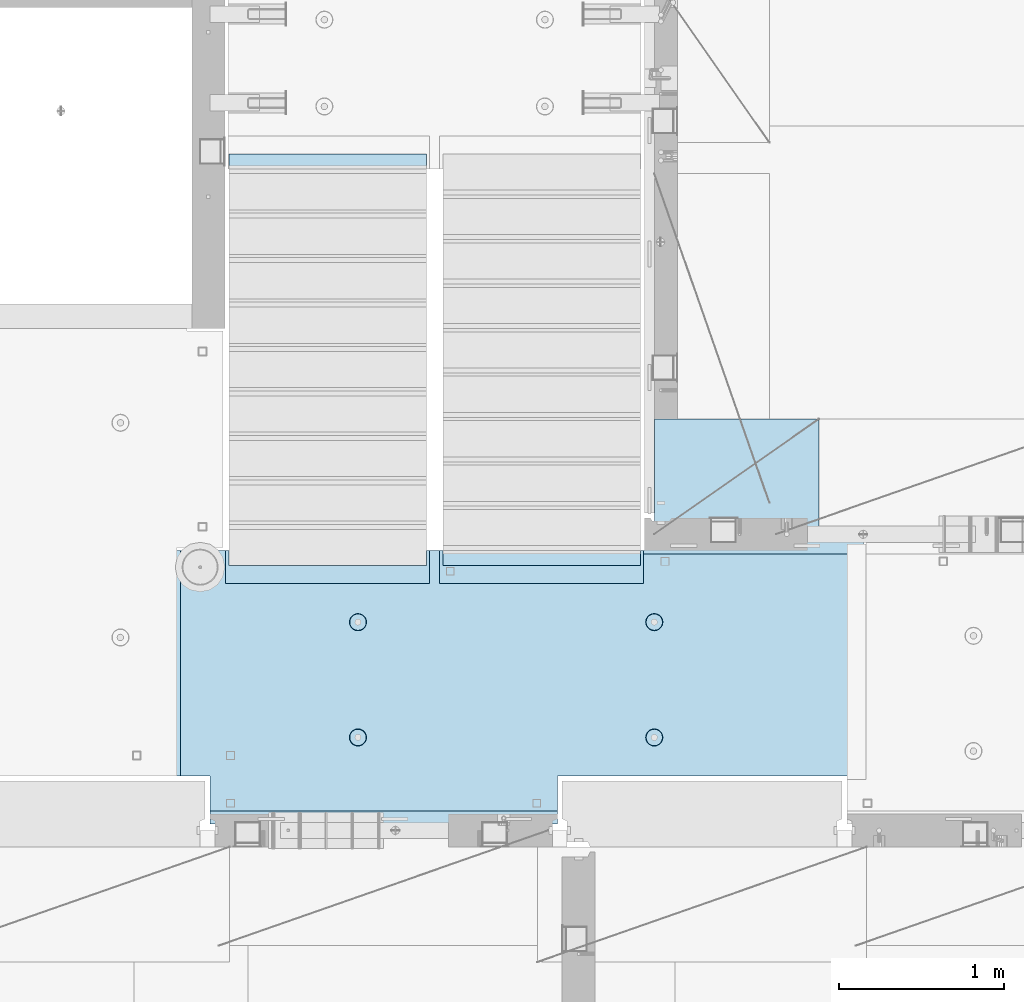
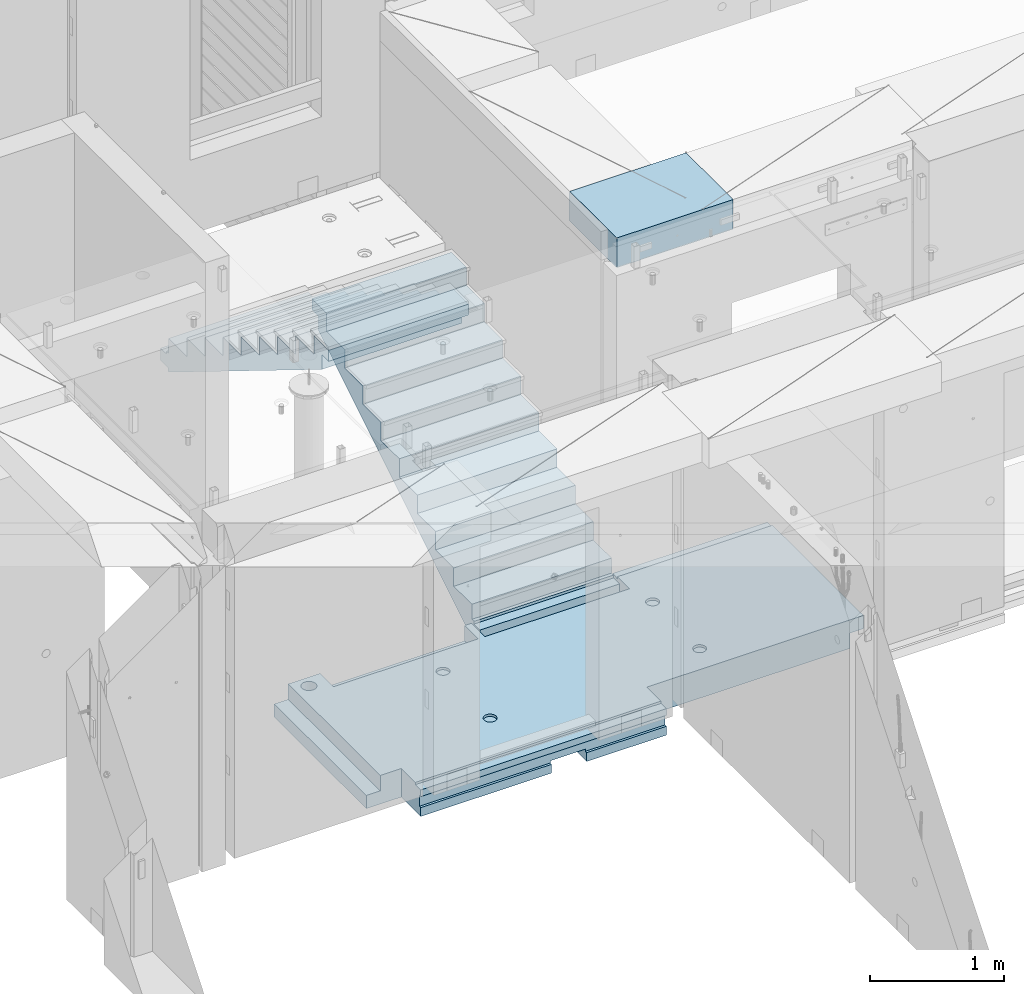
# One storey, part 207 of 352: 3 plates, 1 slab, 4 elements without a shape of their own.
"""IFC2X3 building model written with IfcOpenShell, lengths in millimetres."""

import ifcopenshell
import ifcopenshell.guid

model = None  # the IFC model being written
_history = None  # IfcOwnerHistory: only IFC2X3 demands one
_inside = {}  # id of a spatial element -> (the spatial element, [elements in it])
_under = {}  # id of a project, library or spatial element -> (it, [spatial elements below it])
_declared = {}  # id of a project -> (the project, [libraries it declares])
_typed = {}  # id of a type object -> (the type object, [elements of that type])
_made_of = {}  # id of a material, layer set ... -> (it, [elements and type objects made of it])


def new_model(schema):
    """Start an empty IFC model of exactly this schema.

    Asked for "IFC4X3", IfcOpenShell would pick the latest addendum, in which some entities
    have other attributes; the version numbers below select the first issue.
    IFC2X3 requires an IfcOwnerHistory on every rooted entity: one is made here for all.
    """
    global model, _history
    if schema == "IFC4X3":
        model = ifcopenshell.file(schema_version=(4, 3, 0, 0))
    else:
        model = ifcopenshell.file(schema=schema)
    _inside.clear()
    _under.clear()
    _declared.clear()
    _typed.clear()
    _made_of.clear()
    _history = None
    if model.schema == "IFC2X3":
        org = make("IfcOrganization", Name="unknown")
        user = make(
            "IfcPersonAndOrganization",
            ThePerson=make("IfcPerson", FamilyName="unknown"),
            TheOrganization=org,
        )
        app = make(
            "IfcApplication",
            ApplicationDeveloper=org,
            Version="unknown",
            ApplicationFullName="unknown",
            ApplicationIdentifier="unknown",
        )
        _history = make(
            "IfcOwnerHistory",
            OwningUser=user,
            OwningApplication=app,
            ChangeAction="ADDED",
            CreationDate=0,
        )
    return model


def make(cls, **values):
    """One entity of the class cls with the attributes given. An attribute that is None is left unset."""
    return model.create_entity(
        cls, **{name: value for name, value in values.items() if value is not None}
    )


def rooted(cls, **values):
    """An entity with a GlobalId (a new one), such as an element, a storey or a relation."""
    return make(cls, GlobalId=ifcopenshell.guid.new(), OwnerHistory=_history, **values)


def si_unit(unit_type, name, prefix=None):
    """IfcSIUnit, for example si_unit("LENGTHUNIT", "METRE", prefix="MILLI")."""
    return make("IfcSIUnit", UnitType=unit_type, Prefix=prefix, Name=name)


def assignment(units):
    """IfcUnitAssignment: the units of a project."""
    return None if units is None else make("IfcUnitAssignment", Units=units)


def point(xyz):
    """IfcCartesianPoint."""
    return None if xyz is None else make("IfcCartesianPoint", Coordinates=xyz)


def direction(xyz):
    """IfcDirection."""
    return None if xyz is None else make("IfcDirection", DirectionRatios=xyz)


def frame(location, z_axis=None, x_axis=None):
    """IfcAxis2Placement3D, a coordinate frame: its origin and axes. An axis left out is left unset."""
    return make(
        "IfcAxis2Placement3D",
        Location=point(location),
        Axis=direction(z_axis),
        RefDirection=direction(x_axis),
    )


def origin_with_axes():
    """The frame at (0, 0, 0) with the z axis (0, 0, 1) and the x axis (1, 0, 0) written out."""
    return frame((0.0, 0.0, 0.0), z_axis=(0.0, 0.0, 1.0), x_axis=(1.0, 0.0, 0.0))


def place(relative_to, where):
    """IfcLocalPlacement: puts the frame where relative to a parent placement (None: the world)."""
    return make(
        "IfcLocalPlacement", PlacementRelTo=relative_to, RelativePlacement=where
    )


def context(
    kind, dimensions, precision=None, world=None, true_north=None, identifier=None
):
    """IfcGeometricRepresentationContext, for example the 3D "Model" context."""
    return make(
        "IfcGeometricRepresentationContext",
        ContextIdentifier=identifier,
        ContextType=kind,
        CoordinateSpaceDimension=dimensions,
        Precision=precision,
        WorldCoordinateSystem=world,
        TrueNorth=true_north,
    )


def subcontext(parent, identifier, kind, view, scale=None):
    """IfcGeometricRepresentationSubContext, for example "Body" below "Model"."""
    return make(
        "IfcGeometricRepresentationSubContext",
        ContextIdentifier=identifier,
        ContextType=kind,
        ParentContext=parent,
        TargetScale=scale,
        TargetView=view,
    )


def project(units=None, contexts=None):
    """IfcProject with its units and contexts."""
    return rooted(
        "IfcProject",
        Name="project",
        RepresentationContexts=contexts,
        UnitsInContext=assignment(units),
    )


def spatial(cls, under=None, at=None, **own):
    """A site, building, storey or space (cls), placed at a placement, below another one or the project."""
    s = rooted(cls, ObjectPlacement=at, **own)
    if under is not None:
        _under.setdefault(under.id(), (under, []))[1].append(s)
    return s


def faces_of(points, faces, orient=None, outer=None):
    """IfcFace entities. A face is a list of loops; a loop is a list of indices into points, from 0.

    orient and outer hold one flag for each loop. By default every Orientation is true, the
    first loop of a face is its IfcFaceOuterBound and the others are IfcFaceBound.
    """
    made = []
    for i, loops in enumerate(faces):
        bounds = []
        for j, loop in enumerate(loops):
            is_outer = j == 0 if outer is None else outer[i][j]
            bounds.append(
                make(
                    "IfcFaceOuterBound" if is_outer else "IfcFaceBound",
                    Bound=make("IfcPolyLoop", Polygon=[points[k] for k in loop]),
                    Orientation=True if orient is None else orient[i][j],
                )
            )
        made.append(make("IfcFace", Bounds=bounds))
    return made


def faceted_brep(points, faces, orient=None, outer=None, voids=None):
    """IfcFacetedBrep: a solid bounded by flat faces; with voids (closed shells), ...WithVoids."""
    shared = [point(p) for p in points]
    hull = make("IfcClosedShell", CfsFaces=faces_of(shared, faces, orient, outer))
    if voids is None:
        return make("IfcFacetedBrep", Outer=hull)
    return make(
        "IfcFacetedBrepWithVoids",
        Outer=hull,
        Voids=[
            make(cls, CfsFaces=faces_of(shared, fs, o, b)) for cls, fs, o, b in voids
        ],
    )


def shape(context_of_items, identifier, shape_type, items):
    """IfcShapeRepresentation: the items that make up one representation, for example the "Body"."""
    return make(
        "IfcShapeRepresentation",
        ContextOfItems=context_of_items,
        RepresentationIdentifier=identifier,
        RepresentationType=shape_type,
        Items=items,
    )


def material(Name=None, Category=None):
    """IfcMaterial."""
    return make("IfcMaterial", Name=Name, Category=Category)


def made_of(thing, what):
    """Note that an element or type object is made of a material, layer set ...; save() writes the relation."""
    if what is not None:
        _made_of.setdefault(what.id(), (what, []))[1].append(thing)
    return thing


def type_object(cls, material=None, **own):
    """A type object (cls), such as IfcWallType, which elements share."""
    return made_of(rooted(cls, **own), material)


def element(
    cls,
    number,
    at=None,
    inside=None,
    cuts=None,
    type_object=None,
    material=None,
    context=None,
    identifier="Body",
    shape_type=None,
    held_by="IfcProductDefinitionShape",
    body=None,
    shapes=None,
    **own,
):
    """One element of the class cls, such as IfcWall. Its Tag is "e" and its number.

    at: its placement. inside: the storey or other place that contains it. cuts: it is an
    opening in that element (IfcRelVoidsElement). A single representation is given by context,
    identifier, shape_type and body (its items); several are given by shapes. held_by: the class
    of the entity that holds the representations. save() writes the other relations.
    """
    e = rooted(cls, Tag="e%d" % number, ObjectPlacement=at, **own)
    if body is not None:
        shapes = [shape(context, identifier, shape_type, body)]
    if shapes is not None:
        e.Representation = make(held_by, Representations=shapes)
    if inside is not None:
        _inside.setdefault(inside.id(), (inside, []))[1].append(e)
    if cuts is not None:
        rooted(
            "IfcRelVoidsElement", RelatingBuildingElement=cuts, RelatedOpeningElement=e
        )
    if type_object is not None:
        _typed.setdefault(type_object.id(), (type_object, []))[1].append(e)
    return made_of(e, material)


def aggregate(whole, parts):
    """IfcRelAggregates: a whole, such as a stair, and the parts it consists of."""
    return rooted("IfcRelAggregates", RelatingObject=whole, RelatedObjects=parts)


def save(model, path):
    """Write the relations noted so far, then the file.

    IfcRelAggregates (storeys below a building ...), IfcRelContainedInSpatialStructure (elements
    in a storey), IfcRelDefinesByType, IfcRelAssociatesMaterial and IfcRelDeclares: one each for
    every whole, place, type object, material and project.
    """
    for whole, parts in _under.values():
        aggregate(whole, parts)
    for where, things in _inside.values():
        rooted(
            "IfcRelContainedInSpatialStructure",
            RelatedElements=things,
            RelatingStructure=where,
        )
    for kind, things in _typed.values():
        rooted("IfcRelDefinesByType", RelatedObjects=things, RelatingType=kind)
    for what, things in _made_of.values():
        rooted("IfcRelAssociatesMaterial", RelatedObjects=things, RelatingMaterial=what)
    for by, libraries in _declared.values():
        rooted("IfcRelDeclares", RelatingContext=by, RelatedDefinitions=libraries)
    model.write(path)


model = new_model("IFC2X3")

# Units and contexts
model_context = context("Model", 3, precision=1e-05, world=origin_with_axes())
body_context = subcontext(model_context, "Body", "Model", "MODEL_VIEW")
ifc_project = project(units=[si_unit("LENGTHUNIT", "METRE", prefix="MILLI"), si_unit("AREAUNIT", "SQUARE_METRE"), si_unit("VOLUMEUNIT", "CUBIC_METRE"), si_unit("MASSUNIT", "GRAM", prefix="KILO"), si_unit("TIMEUNIT", "SECOND"), si_unit("PLANEANGLEUNIT", "RADIAN"), si_unit("SOLIDANGLEUNIT", "STERADIAN"), si_unit("THERMODYNAMICTEMPERATUREUNIT", "DEGREE_CELSIUS"), si_unit("LUMINOUSINTENSITYUNIT", "LUMEN")], contexts=[model_context])

# Site, building, storey
site_placement = place(None, origin_with_axes())
site = spatial("IfcSite", under=ifc_project, at=site_placement, CompositionType="ELEMENT")
building_placement = place(site_placement, origin_with_axes())
building = spatial("IfcBuilding", under=site, at=building_placement, CompositionType="ELEMENT")
storey_placement = place(building_placement, origin_with_axes())
storey = spatial("IfcBuildingStorey", under=building, at=storey_placement, Name="6", CompositionType="ELEMENT", Elevation=0.0)

# Assembly, slab
assembly_1_placement = place(storey_placement, origin_with_axes())
assembly_1 = element("IfcElementAssembly", 1, at=assembly_1_placement, inside=storey, AssemblyPlace="NOTDEFINED", PredefinedType="REINFORCEMENT_UNIT")
ifc_material_1 = material(Name="CONCRETE/C25/30")
slab_type = type_object("IfcSlabType", PredefinedType="NOTDEFINED")
slab_placement = place(assembly_1_placement, frame((23540.0159390845, 15510.0026483125, 96620.0), z_axis=(-0.999999999997437, -2.26400000064461e-06, 0.0), x_axis=(-2.2639999995273e-06, 0.999999999997437, 0.0)))
slab = element("IfcSlab", 2, at=slab_placement, type_object=slab_type, material=ifc_material_1, PredefinedType="FLOOR", context=body_context, shape_type="Brep", body=[
    faceted_brep([(-269.991394356101, 30.0, 2845.00213671412), (-79.9935682977648, 30.0, 2845.00213671301), (-79.9942474988402, 30.0, 2545.001661275), (-269.991475956112, 30.0, 2545.00209142873), (-79.9935682977648, 130.0, 2845.00213671301), (-269.991394356102, 50.0011356208415, 2845.00213671412), (-289.993566176285, 50.0011356208415, 2845.00213671423), (-289.993566176285, 130.0, 2845.00213671423), (-79.9942474988402, 130.0, 2545.001661275), (-289.994243058944, 130.0, 2545.00213671499), (-289.994243058944, 50.0011356208415, 2545.00213671499), (-269.991475956114, 50.0011356208415, 2545.00209142873), (250.667816023648, -110.0, 1223.00869116667), (264.606228919523, -110.0, 1230.11066726268), (275.667816023648, -110.0, 1241.1722543668), (282.76979211966, -110.0, 1255.11066726268), (285.216966304903, -110.0, 1270.56151698143), (282.769792119658, -110.0, 1286.01236670018), (275.667816023648, -110.0, 1299.95077959605), (264.606228919525, -110.0, 1311.01236670018), (250.667816023648, -110.0, 1318.11434279619), (235.216966304901, -110.0, 1320.56151698143), (219.766116586154, -110.0, 1318.11434279619), (205.827703690276, -110.0, 1311.01236670018), (194.766116586154, -110.0, 1299.95077959605), (187.664140490142, -110.0, 1286.01236670018), (185.216966304899, -110.0, 1270.56151698143), (187.664140490144, -110.0, 1255.11066726268), (194.766116586154, -110.0, 1241.1722543668), (205.827703690276, -110.0, 1230.11066726268), (219.766116586154, -110.0, 1223.00869116667), (235.216966304901, -110.0, 1220.56151698143), (251.370127374501, -130.0, 1220.84719908418), (235.216966304901, -130.0, 1218.2887897087), (265.942104492917, -130.0, 1228.27199227546), (277.506491010863, -130.0, 1239.83637879341), (284.931284202146, -130.0, 1254.40835591183), (287.489693577627, -130.0, 1270.56151698143), (284.931284202146, -130.0, 1286.71467805103), (277.506491010861, -130.0, 1301.28665516945), (265.942104492917, -130.0, 1312.85104168739), (251.370127374501, -130.0, 1320.27583487867), (235.216966304901, -130.0, 1322.83424425416), (219.063805235301, -130.0, 1320.27583487867), (204.491828116883, -130.0, 1312.85104168739), (192.927441598938, -130.0, 1301.28665516945), (185.502648407655, -130.0, 1286.71467805103), (182.944239032175, -130.0, 1270.56151698143), (185.502648407655, -130.0, 1254.40835591183), (192.92744159894, -130.0, 1239.83637879341), (204.491828116883, -130.0, 1228.27199227546), (219.063805235301, -130.0, 1220.84719908418), (1370.00988769532, 9.99999999994179, 4270.0029296875), (0.00703133410206647, 9.99999999994179, 4270.00341796875), (0.00594789032584231, 9.99999999994179, 4150.00335886026), (1370.00950450419, 9.99999999994179, 4150.0022190173), (1370.00988769532, 130.0, 4270.0029296875), (0.00703133410206647, 130.0, 4270.00341796875), (-289.995788574217, 50.0011356208415, 1860.01696777343), (-269.99166227209, 50.0011356208415, 1860.01689198933), (-289.995788574217, 130.0, 1860.01696777343), (1410.00403637765, -10.0000000000582, 115.00218916441), (-0.000334584017764428, -10.0000000000582, 115.003668258996), (-0.000334584015945438, 130.0, 115.003668258996), (1430.00436377147, 130.0, 115.002168181909), (1430.00283514406, 50.0011356437899, 115.002168184747), (1410.00403637764, 50.0011356208415, 115.002189163421), (1430.00659179688, 130.0, 1330.01220703125), (1370.00036621094, 130.0, 1330.01281738281), (1370.00036621094, -110.000000000073, 1330.01281738281), (1430.00659179688, -110.000000000073, 1330.01220703125), (1430.00656714066, -110.000000000073, 1.33804860524833e-08), (1350.00656713971, -110.000000000073, -1.09139364212751e-10), (1350.00656713971, -130.0, -9.31322574615479e-10), (0.0, -130.0, -3.63797880709171e-12), (0.0, -10.0, 0.0), (1410.00416932017, -10.0000000000582, 1.69893610291183e-09), (1410.00416932017, -49.9988643791585, 5.89352566748858e-10), (1430.00416932019, -49.9988643791585, 2.83398549072444e-09), (1430.00277003324, 50.0011356208415, 1270.01537795496), (1430.00277003324, -49.9988643791585, 1270.01537795496), (1410.00277003325, 50.0011356208415, 1270.01535591496), (1410.00277003325, -49.9988643791585, 1270.01535591496), (-0.00148380931932479, -130.0, 510.016937255856), (-0.00148380931932479, 130.0, 510.016937255856), (0.00156440050341189, -130.0, 1860.01586914062), (0.00156440050341189, 130.0, 1860.01586914062), (-209.991713751984, -130.000000000058, 1860.01666468411), (-209.996345203012, -130.0, 3970.01713194715), (-209.996345203012, -110.000000000058, 3970.01713194715), (-209.991713751984, -110.000000000058, 1860.01666468411), (-289.991027832028, -110.000000000058, 3970.01733398437), (-289.995788574217, -110.000000000058, 1860.01696777343), (-289.991027832028, -49.9988643791585, 3970.01733398437), (-289.995788574217, -49.9988643791585, 1860.01696777343), (-269.99166227209, -49.9988643791585, 1860.01689198933), (-289.991027832028, 50.0011356208415, 3970.01733398437), (-289.991027832028, 130.0, 3970.01733398437), (-269.991088351981, 50.0011356208415, 3970.01728347186), (-269.991088351981, -49.9988643791585, 3970.01728347186), (0.00432284502676339, -130.0, 3970.0166015625), (0.00432284502676339, 130.0, 3970.0166015625), (0.00594789032584231, -130.0, 4150.00335886026), (1370.00950450419, -130.000000000058, 4150.0022190173), (1370.00860847198, 9.99639270307671, 3875.01157736929), (1170.00318277859, 9.99639270307671, 3875.01203018158), (1170.00037541444, 9.99639270307671, 2635.01019913007), (1370.00459258838, 9.99639270307671, 2635.00974632052), (1370.00860847197, -130.000000000058, 3875.01157736929), (1170.00318277859, -130.000000000029, 3875.01203018158), (1170.00037541444, -130.000000000029, 2635.01019913007), (1370.00459258838, -130.000000000029, 2635.00974632052), (1370.00439827764, -130.000000000029, 2575.01157737549), (1170.00023957859, -130.000000000029, 2575.01203018491), (1170.00023957859, 9.99639270307671, 2575.01203018491), (1370.00439827764, 9.99639270307671, 2575.01157737549), (1169.99743221444, -130.000000000029, 1335.0101991334), (1169.99743221444, 9.99639270307671, 1335.0101991334), (1370.00038239405, 9.99639270307671, 1335.00974632672), (1370.00038239405, -110.000000000073, 1335.00974632672), (1350.00004294686, -110.000000000073, 1335.00979160748), (1350.00004294686, -130.000000000073, 1335.00979160748), (920.332855772751, -110.0, 1318.11282667454), (906.394410719273, -110.0, 1311.01091369173), (895.332773528397, -110.0, 1299.94937667459), (888.230734319324, -110.0, 1286.01099593661), (885.78349017266, -110.0, 1270.56015729882), (888.230594396427, -110.0, 1255.10929649942), (895.332507379233, -110.0, 1241.17085144594), (906.394044396377, -110.0, 1230.10921425507), (920.332425134358, -110.0, 1223.00717504599), (935.783263772144, -110.0, 1220.55993089933), (951.234124571543, -110.0, 1223.0070351231), (965.172569625021, -110.0, 1230.10894810591), (976.234206815898, -110.0, 1241.17048512305), (983.33624602497, -110.0, 1255.10886586103), (985.783490171634, -110.0, 1270.55970449882), (983.336385947867, -110.0, 1286.01056529821), (976.234472965061, -110.0, 1299.94901035169), (965.172935947918, -110.0, 1311.01064754257), (951.234555209936, -110.0, 1318.11268675164), (935.783716572147, -110.0, 1320.5599308983), (951.936426135147, -130.0, 1220.84553986057), (935.783253481237, -130.0, 1218.28720362663), (966.508436872882, -130.0, 1228.27026706986), (978.072875754253, -130.0, 1239.83460122415), (985.497734927369, -130.0, 1254.40654472295), (988.05621744434, -130.0, 1270.55969420791), (985.497881210395, -130.0, 1286.71286686182), (978.073154001104, -130.0, 1301.28487759955), (966.508819846818, -130.0, 1312.84931648092), (951.936876348012, -130.0, 1320.27417565404), (935.783726863054, -130.0, 1322.83265817101), (919.630554209147, -130.0, 1320.27432193707), (905.058543471412, -130.0, 1312.84959472777), (893.494104590041, -130.0, 1301.28526057349), (886.069245416922, -130.0, 1286.71331707469), (883.510762899954, -130.0, 1270.56016758973), (886.069099133892, -130.0, 1254.40699493582), (893.49382634319, -130.0, 1239.83498419809), (905.058160497476, -130.0, 1228.27054531671), (919.630103996282, -130.0, 1220.84568614359), (920.336931380272, -110.0, 3118.29282666992), (906.398486326791, -110.0, 3111.19091368712), (895.336849135918, -110.0, 3100.12937666997), (888.234809926846, -110.0, 3086.19099593199), (885.787565780181, -110.0, 3070.7401572942), (888.234670003949, -110.0, 3055.28929649481), (895.336582986754, -110.0, 3041.35085144133), (906.398120003898, -110.0, 3030.28921425045), (920.33650074188, -110.0, 3023.18717504138), (935.787339379665, -110.0, 3020.73993089472), (951.238200179065, -110.0, 3023.18703511849), (965.176645232543, -110.0, 3030.28894810129), (976.238282423419, -110.0, 3041.35048511844), (983.340321632491, -110.0, 3055.28886585642), (985.787565779156, -110.0, 3070.7397044942), (983.340461555388, -110.0, 3086.1905652936), (976.238548572583, -110.0, 3100.12901034708), (965.177011555439, -110.0, 3111.19064753796), (951.238630817454, -110.0, 3118.29268674703), (935.787792179664, -110.0, 3120.73993089369), (951.940501742669, -130.000000000015, 3021.02553985595), (935.787329088758, -130.000000000015, 3018.46720362201), (966.512512480404, -130.000000000015, 3028.45026706525), (978.076951361778, -130.000000000015, 3040.01460121954), (985.50181053489, -130.000000000015, 3054.58654471834), (988.060293051862, -130.000000000015, 3070.73969420329), (985.501956817916, -130.000000000015, 3086.89286685721), (978.077229608625, -130.000000000015, 3101.46487759494), (966.51289545434, -130.000000000015, 3113.02931647631), (951.940951955534, -130.000000000015, 3120.45417564943), (935.787802470575, -130.000000000015, 3123.01265816639), (919.634629816665, -130.000000000015, 3120.45432193246), (905.062619078933, -130.000000000015, 3113.02959472316), (893.498180197559, -130.000000000015, 3101.46526056888), (886.07332102444, -130.000000000015, 3086.89331707007), (883.514838507475, -130.000000000015, 3070.74016758511), (886.073174741414, -130.000000000015, 3054.5869949312), (893.497901950712, -130.000000000015, 3040.01498419347), (905.062236104997, -130.000000000015, 3028.4505453121), (919.634179603803, -130.000000000015, 3021.02568613898), (250.671891631169, -110.0, 3023.18869116206), (264.610304527045, -110.0, 3030.29066725807), (275.671891631167, -110.0, 3041.35225436219), (282.773867727179, -110.0, 3055.29066725806), (285.221041912424, -110.0, 3070.74151697681), (282.773867727179, -110.0, 3086.19236669556), (275.671891631169, -110.0, 3100.13077959144), (264.610304527047, -110.0, 3111.19236669556), (250.671891631169, -110.0, 3118.29434279157), (235.221041912422, -110.0, 3120.74151697681), (219.770192193675, -110.0, 3118.29434279157), (205.831779297798, -110.0, 3111.19236669556), (194.770192193675, -110.0, 3100.13077959144), (187.668216097663, -110.0, 3086.19236669556), (185.22104191242, -110.0, 3070.74151697681), (187.668216097663, -110.0, 3055.29066725806), (194.770192193673, -110.0, 3041.35225436219), (205.831779297798, -110.0, 3030.29066725807), (219.770192193673, -110.0, 3023.18869116206), (235.221041912422, -110.0, 3020.74151697681), (251.374202982022, -130.0, 3021.02719907957), (235.221041912422, -130.0, 3018.46878970409), (265.946180100438, -130.0, 3028.45199227085), (277.510566618384, -130.0, 3040.0163787888), (284.935359809668, -130.0, 3054.58835590722), (287.493769185148, -130.0, 3070.74151697681), (284.935359809668, -130.0, 3086.89467804641), (277.510566618383, -130.0, 3101.46665516483), (265.946180100438, -130.0, 3113.03104168278), (251.374202982022, -130.0, 3120.45583487406), (235.22104191242, -130.0, 3123.01424424954), (219.067880842822, -130.0, 3120.45583487406), (204.495903724404, -130.0, 3113.03104168278), (192.93151720646, -130.0, 3101.46665516483), (185.506724015177, -130.0, 3086.89467804641), (182.948314639694, -130.0, 3070.74151697681), (185.506724015177, -130.0, 3054.58835590722), (192.93151720646, -130.0, 3040.0163787888), (204.495903724404, -130.0, 3028.45199227085), (219.06788084282, -130.0, 3021.02719907957), (1234.74413944682, -130.000000000029, 3981.4733287671), (1221.47026497402, -130.000000000029, 3994.74726334413), (1212.94793152671, -130.000000000029, 4011.47337811379), (1210.0113644813, -130.000000000029, 4030.01440442472), (1212.94801548044, -130.000000000029, 4048.55541743869), (1221.47042466352, -130.000000000029, 4065.28149361904), (1234.74435924055, -130.000000000029, 4078.55536809184), (1251.47047401021, -130.000000000029, 4087.07770153915), (1270.01150032114, -130.000000000029, 4090.01426858456), (1288.55251333511, -130.000000000029, 4087.07761758541), (1305.27858951547, -130.000000000029, 4078.55520840234), (1318.55246398826, -130.000000000029, 4065.28127382531), (1327.07479743557, -130.000000000029, 4048.55515905565), (1330.01136448099, -130.000000000029, 4030.01413274472), (1327.07471348184, -130.000000000029, 4011.47311973075), (1318.55230429877, -130.000000000029, 3994.74704355039), (1305.27836972173, -130.000000000029, 3981.4731690776), (1288.55225495208, -130.000000000029, 3972.95083563029), (1270.01122864114, -130.000000000029, 3970.01426858487), (1251.47021562717, -130.000000000029, 3972.95091958403), (1305.27836972173, 130.0, 3981.4731690776), (1288.55225495208, 130.0, 3972.95083563029), (1318.55230429877, 130.0, 3994.74704355039), (1327.07471348184, 130.0, 4011.47311973075), (1330.01136448099, 130.0, 4030.01413274472), (1327.07479743557, 130.0, 4048.55515905565), (1318.55246398826, 130.0, 4065.28127382531), (1305.27858951547, 130.0, 4078.55520840234), (1288.55251333511, 130.0, 4087.07761758541), (1270.01150032114, 130.0, 4090.01426858456), (1251.47047401021, 130.0, 4087.07770153915), (1234.74435924055, 130.0, 4078.55536809184), (1221.47042466352, 130.0, 4065.28149361904), (1212.94801548044, 130.0, 4048.55541743869), (1210.0113644813, 130.0, 4030.01440442472), (1212.94793152671, 130.0, 4011.47337811379), (1221.47026497402, 130.0, 3994.74726334413), (1234.74413944682, 130.0, 3981.4733287671), (1251.47021562717, 130.0, 3972.95091958403), (1270.01122864114, 130.0, 3970.01426858487)], [[[0, 1, 2, 3]], [[4, 1, 0, 5, 6, 7]], [[8, 2, 1, 4]], [[9, 10, 11, 3, 2, 8]], [[12, 13, 14, 15, 16, 17, 18, 19, 20, 21, 22, 23, 24, 25, 26, 27, 28, 29, 30, 31]], [[32, 12, 31, 33]], [[34, 13, 12, 32]], [[35, 14, 13, 34]], [[36, 15, 14, 35]], [[37, 16, 15, 36]], [[38, 17, 16, 37]], [[39, 18, 17, 38]], [[40, 19, 18, 39]], [[41, 20, 19, 40]], [[42, 21, 20, 41]], [[43, 22, 21, 42]], [[44, 23, 22, 43]], [[45, 24, 23, 44]], [[46, 25, 24, 45]], [[47, 26, 25, 46]], [[48, 27, 26, 47]], [[49, 28, 27, 48]], [[50, 29, 28, 49]], [[51, 30, 29, 50]], [[33, 31, 30, 51]], [[52, 53, 54, 55]], [[56, 57, 53, 52]], [[58, 59, 11, 10]], [[60, 58, 10, 9]], [[61, 62, 63, 64, 65, 66]], [[67, 68, 69, 70]], [[71, 72, 73, 74, 75, 76, 77, 78]], [[79, 65, 64, 67, 70, 71, 78, 80]], [[65, 79, 81, 66]], [[80, 82, 81, 79]], [[78, 77, 82, 80]], [[76, 61, 66, 81, 82, 77]], [[75, 62, 61, 76]], [[74, 83, 84, 63, 62, 75]], [[83, 85, 86, 84]], [[87, 88, 89, 90]], [[90, 89, 91, 92]], [[92, 91, 93, 94]], [[58, 60, 86, 85, 87, 90, 92, 94, 95, 59]], [[96, 97, 7, 6]], [[98, 96, 6, 5]], [[59, 95, 99, 98, 5, 0, 3, 11]], [[94, 93, 99, 95]], [[91, 89, 88, 100, 101, 97, 96, 98, 99, 93]], [[53, 57, 101, 100, 102, 54]], [[103, 55, 54, 102]], [[104, 105, 106, 107]], [[108, 109, 105, 104]], [[110, 106, 105, 109]], [[111, 107, 106, 110]], [[112, 113, 114, 115]], [[116, 117, 114, 113]], [[115, 114, 117, 118]], [[69, 68, 56, 52, 55, 103, 108, 104, 107, 111, 112, 115, 118, 119]], [[72, 71, 70, 69, 119, 120]], [[73, 72, 120, 121]], [[119, 118, 117, 116, 121, 120]], [[122, 123, 124, 125, 126, 127, 128, 129, 130, 131, 132, 133, 134, 135, 136, 137, 138, 139, 140, 141]], [[142, 132, 131, 143]], [[144, 133, 132, 142]], [[145, 134, 133, 144]], [[146, 135, 134, 145]], [[147, 136, 135, 146]], [[148, 137, 136, 147]], [[149, 138, 137, 148]], [[150, 139, 138, 149]], [[151, 140, 139, 150]], [[152, 141, 140, 151]], [[153, 122, 141, 152]], [[154, 123, 122, 153]], [[155, 124, 123, 154]], [[156, 125, 124, 155]], [[157, 126, 125, 156]], [[158, 127, 126, 157]], [[159, 128, 127, 158]], [[160, 129, 128, 159]], [[161, 130, 129, 160]], [[143, 131, 130, 161]], [[162, 163, 164, 165, 166, 167, 168, 169, 170, 171, 172, 173, 174, 175, 176, 177, 178, 179, 180, 181]], [[182, 172, 171, 183]], [[184, 173, 172, 182]], [[185, 174, 173, 184]], [[186, 175, 174, 185]], [[187, 176, 175, 186]], [[188, 177, 176, 187]], [[189, 178, 177, 188]], [[190, 179, 178, 189]], [[191, 180, 179, 190]], [[192, 181, 180, 191]], [[193, 162, 181, 192]], [[194, 163, 162, 193]], [[195, 164, 163, 194]], [[196, 165, 164, 195]], [[197, 166, 165, 196]], [[198, 167, 166, 197]], [[199, 168, 167, 198]], [[200, 169, 168, 199]], [[201, 170, 169, 200]], [[183, 171, 170, 201]], [[202, 203, 204, 205, 206, 207, 208, 209, 210, 211, 212, 213, 214, 215, 216, 217, 218, 219, 220, 221]], [[222, 202, 221, 223]], [[224, 203, 202, 222]], [[225, 204, 203, 224]], [[226, 205, 204, 225]], [[227, 206, 205, 226]], [[228, 207, 206, 227]], [[229, 208, 207, 228]], [[230, 209, 208, 229]], [[231, 210, 209, 230]], [[232, 211, 210, 231]], [[233, 212, 211, 232]], [[234, 213, 212, 233]], [[235, 214, 213, 234]], [[236, 215, 214, 235]], [[237, 216, 215, 236]], [[238, 217, 216, 237]], [[239, 218, 217, 238]], [[240, 219, 218, 239]], [[241, 220, 219, 240]], [[223, 221, 220, 241]], [[113, 112, 111, 110, 109, 108, 103, 102, 100, 88, 87, 85, 83, 74, 73, 121, 116], [240, 239, 238, 237, 236, 235, 234, 233, 232, 231, 230, 229, 228, 227, 226, 225, 224, 222, 223, 241], [200, 199, 198, 197, 196, 195, 194, 193, 192, 191, 190, 189, 188, 187, 186, 185, 184, 182, 183, 201], [160, 159, 158, 157, 156, 155, 154, 153, 152, 151, 150, 149, 148, 147, 146, 145, 144, 142, 143, 161], [50, 49, 48, 47, 46, 45, 44, 43, 42, 41, 40, 39, 38, 37, 36, 35, 34, 32, 33, 51], [242, 243, 244, 245, 246, 247, 248, 249, 250, 251, 252, 253, 254, 255, 256, 257, 258, 259, 260, 261]], [[258, 262, 263, 259]], [[257, 264, 262, 258]], [[256, 265, 264, 257]], [[255, 266, 265, 256]], [[254, 267, 266, 255]], [[253, 268, 267, 254]], [[252, 269, 268, 253]], [[251, 270, 269, 252]], [[250, 271, 270, 251]], [[249, 272, 271, 250]], [[248, 273, 272, 249]], [[247, 274, 273, 248]], [[246, 275, 274, 247]], [[245, 276, 275, 246]], [[244, 277, 276, 245]], [[243, 278, 277, 244]], [[242, 279, 278, 243]], [[261, 280, 279, 242]], [[260, 281, 280, 261]], [[259, 263, 281, 260]], [[7, 97, 101, 57, 56, 68, 67, 64, 63, 84, 86, 60, 9, 8, 4], [262, 264, 265, 266, 267, 268, 269, 270, 271, 272, 273, 274, 275, 276, 277, 278, 279, 280, 281, 263]]]),
])
aggregate(assembly_1, [slab])

# Assembly, plate
assembly_2_placement = place(storey_placement, origin_with_axes())
assembly_2 = element("IfcElementAssembly", 3, at=assembly_2_placement, inside=storey, Name="E9", AssemblyPlace="NOTDEFINED", PredefinedType="NOTDEFINED")
ifc_material_2 = material(Name="Undefined/C32/40")
plate_type_1 = type_object("IfcPlateType", PredefinedType="NOTDEFINED")
plate_1_placement = place(assembly_2_placement, frame((20285.0002457424, 19199.9998138874, 98260.0), z_axis=(0.0, -1.0, 0.0), x_axis=(0.0, 0.0, -1.0)))
plate_1 = element("IfcPlate", 4, at=plate_1_placement, type_object=plate_type_1, material=ifc_material_2, Name="E9", context=body_context, shape_type="Brep", body=[
    faceted_brep([(0.0, -600.0, 0.0), (0.0, -600.0, 30.0), (0.0, 600.0, 30.0), (0.0, 600.0, 0.0), (-136.699996948242, -600.0, 30.0), (-136.699996948242, 600.0, 30.0), (-136.699996948242, -600.0, 300.0), (-136.699996948242, 600.0, 300.0), (-303.399993896484, -600.0, 300.0), (-303.399993896484, 600.0, 300.0), (-303.399993896484, -600.0, 570.0), (-303.399993896484, 600.0, 570.0), (-470.100006103516, -600.0, 570.0), (-470.100006103516, 600.0, 570.0), (-470.100006103516, -600.0, 840.0), (-470.100006103516, 600.0, 840.0), (-636.799987792969, -600.0, 840.0), (-636.799987792969, 600.0, 840.0), (-636.799987792969, -600.0, 1110.0), (-636.799987792969, 600.0, 1110.0), (-803.5, -600.0, 1110.0), (-803.5, 600.0, 1110.0), (-803.5, -600.0, 1380.0), (-803.5, 600.0, 1380.0), (-970.200012207031, -600.0, 1380.0), (-970.200012207031, 600.0, 1380.0), (-970.200012207031, -600.0, 1650.0), (-970.200012207031, 600.0, 1650.0), (-1136.90002441406, -600.0, 1650.0), (-1136.90002441406, 600.0, 1650.0), (-1136.90002441406, -600.0, 1920.0), (-1136.90002441406, 600.0, 1920.0), (-1303.59997558594, -600.0, 1920.0), (-1303.59997558594, 600.0, 1920.0), (-1303.59997558594, -600.0, 2190.0), (-1303.59997558594, 600.0, 2190.0), (-1470.30004882813, -600.0, 2190.0), (-1470.30004882813, 600.0, 2190.0), (-1470.30004882813, -600.0, 2410.0), (-1470.30004882813, 600.0, 2410.0), (-1370.30004882813, -600.0, 2410.0), (-1370.30004882813, 600.0, 2410.0), (-1370.30004882813, -600.0, 2310.0), (-1370.30004882813, 600.0, 2310.0), (-1236.65991210938, -600.0, 2310.0), (-1236.65991210938, 600.0, 2310.0), (170.0, -600.0, 31.6665592193604), (170.0, 600.0, 31.6665592193604), (170.0, -600.0, 20.0), (170.0, 600.0, 20.0), (135.0, -600.0, 20.0), (135.0, 600.0, 20.0), (135.0, -600.0, -90.0), (135.0, 600.0, -90.0), (25.0, -600.0, -90.0), (25.0, 600.0, -90.0), (25.0, -600.0, 0.0), (25.0, 600.0, 0.0)], [[[0, 1, 2, 3]], [[1, 4, 5, 2]], [[4, 6, 7, 5]], [[6, 8, 9, 7]], [[8, 10, 11, 9]], [[10, 12, 13, 11]], [[12, 14, 15, 13]], [[14, 16, 17, 15]], [[16, 18, 19, 17]], [[18, 20, 21, 19]], [[20, 22, 23, 21]], [[22, 24, 25, 23]], [[24, 26, 27, 25]], [[26, 28, 29, 27]], [[28, 30, 31, 29]], [[30, 32, 33, 31]], [[32, 34, 35, 33]], [[34, 36, 37, 35]], [[36, 38, 39, 37]], [[38, 40, 41, 39]], [[40, 42, 43, 41]], [[42, 44, 45, 43]], [[44, 46, 47, 45]], [[46, 48, 49, 47]], [[48, 50, 51, 49]], [[50, 52, 53, 51]], [[52, 54, 55, 53]], [[54, 56, 57, 55]], [[56, 0, 3, 57]], [[5, 7, 9, 11, 13, 15, 17, 19, 21, 23, 25, 27, 29, 31, 33, 35, 37, 39, 41, 43, 45, 47, 49, 51, 53, 55, 57, 3, 2]], [[56, 54, 52, 50, 48, 46, 44, 42, 40, 38, 36, 34, 32, 30, 28, 26, 24, 22, 20, 18, 16, 14, 12, 10, 8, 6, 4, 1, 0]]]),
])
aggregate(assembly_2, [plate_1])

assembly_3_placement = place(storey_placement, origin_with_axes())
assembly_3 = element("IfcElementAssembly", 5, at=assembly_3_placement, inside=storey, Name="E9", AssemblyPlace="NOTDEFINED", PredefinedType="NOTDEFINED")
plate_2_placement = place(assembly_3_placement, frame((21585.002175553, 16880.001025346, 96759.7036072969), z_axis=(0.0, 1.0, 0.0), x_axis=(0.0, 0.0, -1.0)))
plate_2 = element("IfcPlate", 6, at=plate_2_placement, type_object=plate_type_1, material=ifc_material_2, Name="E9", context=body_context, shape_type="Brep", body=[
    faceted_brep([(0.0, -600.0, 0.0), (0.0, -600.0, 30.0), (0.0, 600.0, 30.0), (0.0, 600.0, 0.0), (-136.699996948242, -600.0, 30.0), (-136.699996948242, 600.0, 30.0), (-136.699996948242, -600.0, 300.0), (-136.699996948242, 600.0, 300.0), (-303.399993896484, -600.0, 300.0), (-303.399993896484, 600.0, 300.0), (-303.399993896484, -600.0, 570.0), (-303.399993896484, 600.0, 570.0), (-470.100006103516, -600.0, 570.0), (-470.100006103516, 600.0, 570.0), (-470.100006103516, -600.0, 840.0), (-470.100006103516, 600.0, 840.0), (-636.799987792969, -600.0, 840.0), (-636.799987792969, 600.0, 840.0), (-636.799987792969, -600.0, 1110.0), (-636.799987792969, 600.0, 1110.0), (-803.5, -600.0, 1110.0), (-803.5, 600.0, 1110.0), (-803.5, -600.0, 1380.0), (-803.5, 600.0, 1380.0), (-970.200012207031, -600.0, 1380.0), (-970.200012207031, 600.0, 1380.0), (-970.200012207031, -600.0, 1650.0), (-970.200012207031, 600.0, 1650.0), (-1136.90002441406, -600.0, 1650.0), (-1136.90002441406, 600.0, 1650.0), (-1136.90002441406, -600.0, 1920.0), (-1136.90002441406, 600.0, 1920.0), (-1303.59997558594, -600.0, 1920.0), (-1303.59997558594, 600.0, 1920.0), (-1303.59997558594, -600.0, 2190.0), (-1303.59997558594, 600.0, 2190.0), (-1470.30004882813, -600.0, 2190.0), (-1470.30004882813, 600.0, 2190.0), (-1470.30004882813, -600.0, 2410.0), (-1470.30004882813, 600.0, 2410.0), (-1370.30004882813, -600.0, 2410.0), (-1370.30004882813, 600.0, 2410.0), (-1370.30004882813, -600.0, 2310.0), (-1370.30004882813, 600.0, 2310.0), (-1236.65991210938, -600.0, 2310.0), (-1236.65991210938, 600.0, 2310.0), (170.0, -600.0, 31.6665592193604), (170.0, 600.0, 31.6665592193604), (170.0, -600.0, 20.0), (170.0, 600.0, 20.0), (135.0, -600.0, 20.0), (135.0, 600.0, 20.0), (135.0, -600.0, -90.0), (135.0, 600.0, -90.0), (25.0, -600.0, -90.0), (25.0, 600.0, -90.0), (25.0, -600.0, 0.0), (25.0, 600.0, 0.0)], [[[0, 1, 2, 3]], [[1, 4, 5, 2]], [[4, 6, 7, 5]], [[6, 8, 9, 7]], [[8, 10, 11, 9]], [[10, 12, 13, 11]], [[12, 14, 15, 13]], [[14, 16, 17, 15]], [[16, 18, 19, 17]], [[18, 20, 21, 19]], [[20, 22, 23, 21]], [[22, 24, 25, 23]], [[24, 26, 27, 25]], [[26, 28, 29, 27]], [[28, 30, 31, 29]], [[30, 32, 33, 31]], [[32, 34, 35, 33]], [[34, 36, 37, 35]], [[36, 38, 39, 37]], [[38, 40, 41, 39]], [[40, 42, 43, 41]], [[42, 44, 45, 43]], [[44, 46, 47, 45]], [[46, 48, 49, 47]], [[48, 50, 51, 49]], [[50, 52, 53, 51]], [[52, 54, 55, 53]], [[54, 56, 57, 55]], [[56, 0, 3, 57]], [[5, 7, 9, 11, 13, 15, 17, 19, 21, 23, 25, 27, 29, 31, 33, 35, 37, 39, 41, 43, 45, 47, 49, 51, 53, 55, 57, 3, 2]], [[56, 54, 52, 50, 48, 46, 44, 42, 40, 38, 36, 34, 32, 30, 28, 26, 24, 22, 20, 18, 16, 14, 12, 10, 8, 6, 4, 1, 0]]]),
])
aggregate(assembly_3, [plate_2])

assembly_4_placement = place(storey_placement, origin_with_axes())
assembly_4 = element("IfcElementAssembly", 7, at=assembly_4_placement, inside=storey, Name="Steel Assembly", AssemblyPlace="NOTDEFINED", PredefinedType="NOTDEFINED")
ifc_material_3 = material()
plate_type_2 = type_object("IfcPlateType", PredefinedType="NOTDEFINED")
plate_3_placement = place(assembly_4_placement, frame((22270.0, 16979.9999999293, 99595.3), z_axis=(0.0, 1.0, 0.0), x_axis=(1.0, 0.0, 0.0)))
plate_3 = element("IfcPlate", 8, at=plate_3_placement, type_object=plate_type_2, material=ifc_material_3, Name="RE1_1/2", context=body_context, shape_type="Brep", body=[
    faceted_brep([(1.81898940354586e-12, -135.0, 1.81898940354586e-12), (0.0, -135.0, 699.999999999996), (0.0, 135.0, 699.999999999996), (1.81898940354586e-12, 135.0, 1.81898940354586e-12), (999.99951171875, -135.0, 700.0), (999.99951171875, 135.0, 700.0), (1000.0, -135.0, 0.0), (1000.0, 135.0, 0.0)], [[[0, 1, 2, 3]], [[1, 4, 5, 2]], [[4, 6, 7, 5]], [[6, 0, 3, 7]], [[5, 7, 3, 2]], [[6, 4, 1, 0]]]),
])
aggregate(assembly_4, [plate_3])

save(model, "model.ifc")
